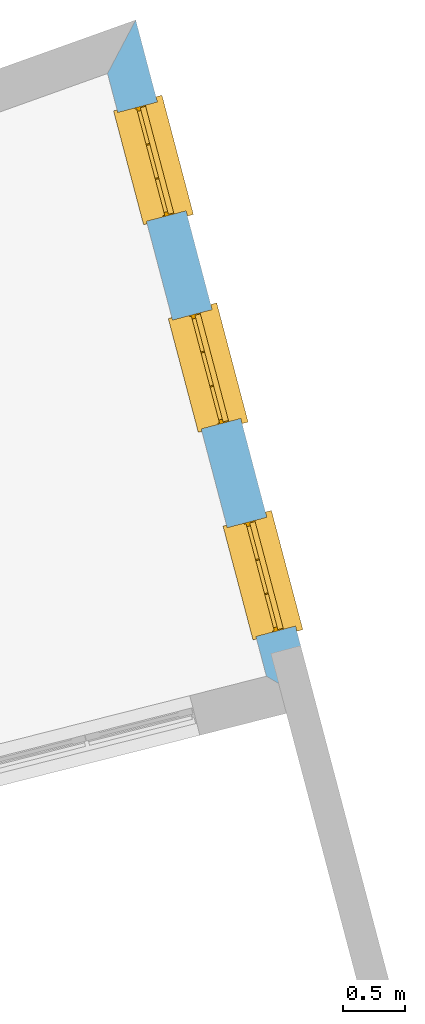
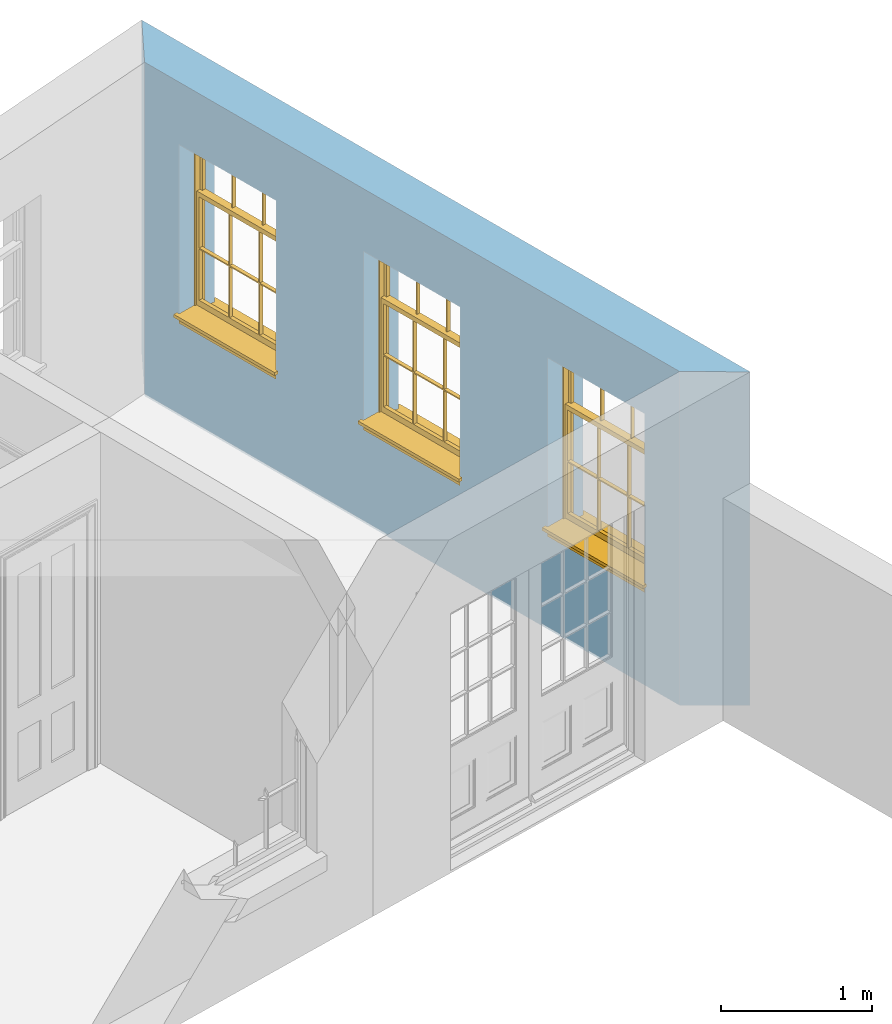
# One storey, part 14 of 15: 3 windows, 3 openings, plus 1 element that does not belong to this part.
"""IFC2X3 building model written with IfcOpenShell, lengths in metres."""

from ifc_helpers import new_model, si_unit, frame, origin, place, context, subcontext, project, spatial, polyline, outline, extrude, faceted_brep, material, layer, layer_set, layer_usage, element, fill, save


model = new_model("IFC2X3")

# Units and contexts
model_context = context("Model", 3, world=origin())
body_context = subcontext(model_context, "Body", "Model", "MODEL_VIEW")
ifc_project = project(units=[si_unit("PLANEANGLEUNIT", "RADIAN"), si_unit("MASSUNIT", "GRAM", prefix="KILO"), si_unit("FORCEUNIT", "NEWTON", prefix="KILO"), si_unit("LENGTHUNIT", "METRE")], contexts=[model_context])

# Site, building, storey
site_placement = place(None, origin())
site = spatial("IfcSite", under=ifc_project, at=site_placement, CompositionType="ELEMENT")
building_placement = place(None, origin())
building = spatial("IfcBuilding", under=site, at=building_placement, Name="Building plot-13", CompositionType="ELEMENT")
storey_placement = place(None, frame((0.0, 0.0, 4.0)))
storey = spatial("IfcBuildingStorey", under=building, at=storey_placement, Name="Floor 0", CompositionType="ELEMENT", Elevation=4.0)

# Wall, openings, windows
ifc_material = material(Name="Masonry")
ifc_layer = layer(ifc_material, 0.33, ventilated=False)
ifc_layer_set = layer_set([ifc_layer], Name="My Wall")
ifc_layer_usage = layer_usage(ifc_layer_set, "AXIS2", "NEGATIVE", 0.08)
wall_placement = place(storey_placement, origin())
wall = element("IfcWallStandardCase", 1, at=wall_placement, inside=storey, material=ifc_layer_usage, Name="exterior", context=body_context, shape_type="SweptSolid", body=[
    extrude(outline(polyline([(79.9817754258731, 47.2487256724398), (80.3857854678444, 47.0107450750622), (78.9265356735152, 52.5462115674965), (78.699089450727, 52.1144212259562), (79.9817754258731, 47.2487256724398)])), origin(), (0.0, 0.0, 1.0), 2.7),
])
opening_1_placement = place(storey_placement, frame((0.0, 0.0, 0.75)))
opening_1 = element("IfcOpeningElement", 2, at=opening_1_placement, cuts=wall, Name="Opening", ObjectType="Opening", context=body_context, shape_type="SweptSolid", body=[
    extrude(outline(polyline([(80.2165274414276, 47.6528024784256), (79.9845597414815, 48.5327405365761), (79.6654613247896, 48.4486203816506), (79.8974290247357, 47.5686823235001), (80.2165274414276, 47.6528024784256)])), origin(), (0.0, 0.0, 1.0), 1.445),
])
opening_2_placement = place(storey_placement, frame((0.0, 0.0, 0.75)))
opening_2 = element("IfcOpeningElement", 3, at=opening_2_placement, cuts=wall, Name="Opening", ObjectType="Opening", context=body_context, shape_type="SweptSolid", body=[
    extrude(outline(polyline([(79.7746976663439, 49.3288239004194), (79.5427299663978, 50.2087619585699), (79.2236315497059, 50.1246418036444), (79.455599249652, 49.2447037454939), (79.7746976663439, 49.3288239004194)])), origin(), (0.0, 0.0, 1.0), 1.445),
])
opening_3_placement = place(storey_placement, frame((0.0, 0.0, 0.75)))
opening_3 = element("IfcOpeningElement", 4, at=opening_3_placement, cuts=wall, Name="Opening", ObjectType="Opening", context=body_context, shape_type="SweptSolid", body=[
    extrude(outline(polyline([(79.3328678912602, 51.0048453224131), (79.1009001913141, 51.8847833805637), (78.7818017746222, 51.8006632256382), (79.0137694745683, 50.9207251674876), (79.3328678912602, 51.0048453224131)])), origin(), (0.0, 0.0, 1.0), 1.445),
])
window_1_placement = place(storey_placement, frame((79.974786216661, 47.5890750883305, 0.75), z_axis=(0.0, 0.0, 1.0), x_axis=(-0.231967699946068, 0.879938058150529, 0.0)))
window_1 = element("IfcWindow", 5, at=window_1_placement, inside=storey, Name="living street window", OverallHeight=1.445, OverallWidth=0.91, context=body_context, shape_type="Brep", held_by="IfcProductRepresentation", body=[
    faceted_brep([(0.876875, -0.105, 0.999097), (0.876875, -0.105, 1.411875), (0.9, -0.105, 1.435), (0.033125, -0.105, 1.411875), (0.033125, -0.105, 0.999097), (0.01, -0.105, 1.435), (0.033125, -0.135, 1.411875), (0.01, -0.135, 1.435), (0.033125, -0.135, 0.999097), (0.876875, -0.135, 1.411875), (0.876875, -0.135, 0.999097), (0.9, -0.135, 1.435), (0.033125, -0.105, 0.960972), (0.01, -0.105, 0.960972), (0.033125, -0.105, 0.548195), (0.876875, -0.105, 0.960972), (0.876875, -0.105, 0.548195), (0.9, -0.105, 0.960972), (0.876875, -0.105, 0.538195), (0.876875, -0.105, 0.125417), (0.9, -0.105, 0.077167), (0.033125, -0.105, 0.125417), (0.033125, -0.105, 0.538195), (0.01, -0.105, 0.077167), (0.9, -0.135, 0.960972), (0.01, -0.135, 0.960972), (-0.0425, -0.25, 0.01), (-0.0425, -0.3, 0.001667), (0.0, -0.25, 0.01), (0.9525, -0.25, 0.01), (0.91, -0.25, 0.01), (0.9525, -0.3, 0.001667), (-0.02, 0.08, 0.077167), (0.0, 0.08, 0.077167), (-0.02, 0.11, 0.077167), (0.0, -0.06, 0.077167), (0.01, -0.06, 0.077167), (0.91, -0.06, 0.077167), (0.91, 0.08, 0.077167), (0.9, -0.06, 0.077167), (0.93, 0.08, 0.077167), (0.93, 0.11, 0.077167), (0.01, -0.105, 0.999097), (0.01, -0.075, 0.999097), (0.9, -0.105, 0.999097), (0.9, -0.075, 0.999097), (0.876875, -0.075, 0.125417), (0.876875, -0.075, 0.538195), (0.9, -0.075, 0.077167), (0.876875, -0.075, 0.548195), (0.876875, -0.075, 0.960972), (0.033125, -0.075, 0.125417), (0.01, -0.075, 0.077167), (0.033125, -0.075, 0.538195), (0.033125, -0.075, 0.960972), (0.033125, -0.075, 0.548195), (-0.02, 0.08, 0.052167), (-0.02, 0.11, 0.052167), (0.93, 0.11, 0.052167), (0.93, 0.08, 0.052167), (0.91, 0.08, 0.052167), (0.0, 0.08, 0.052167), (0.91, -0.15, 0.026667), (0.0, -0.15, 0.026667), (-0.0425, -0.3, -0.123333), (0.9525, -0.3, -0.123333), (-0.0425, -0.25, -0.123333), (0.9525, -0.25, -0.123333), (0.01, -0.06, 1.435), (0.9, -0.06, 1.435), (0.0, -0.06, 1.445), (0.91, -0.06, 1.445), (0.01, -0.15, 0.077167), (0.9, -0.15, 0.077167), (0.592292, -0.105, 0.125417), (0.592292, -0.075, 0.125417), (0.317708, -0.075, 0.125417), (0.317708, -0.105, 0.125417), (0.592292, -0.105, 0.548195), (0.317708, -0.105, 0.548195), (0.317708, -0.105, 0.538195), (0.592292, -0.105, 0.538195), (0.592292, -0.075, 0.548195), (0.317708, -0.075, 0.548195), (0.602292, -0.075, 0.548195), (0.602292, -0.105, 0.548195), (0.317708, -0.075, 0.538195), (0.307708, -0.075, 0.125417), (0.307708, -0.075, 0.538195), (0.602292, -0.075, 0.538195), (0.602292, -0.075, 0.125417), (0.592292, -0.075, 0.538195), (0.307708, -0.075, 0.548195), (0.317708, -0.075, 0.960972), (0.307708, -0.075, 0.960972), (0.602292, -0.075, 0.960972), (0.592292, -0.075, 0.960972), (0.307708, -0.105, 0.538195), (0.307708, -0.105, 0.125417), (0.307708, -0.105, 0.548195), (0.307708, -0.105, 0.960972), (0.592292, -0.105, 0.960972), (0.317708, -0.105, 0.960972), (0.602292, -0.105, 0.960972), (0.602292, -0.105, 0.538195), (0.602292, -0.105, 0.125417), (0.317708, -0.135, 1.411875), (0.307708, -0.135, 1.411875), (0.307708, -0.135, 0.999097), (0.317708, -0.135, 0.999097), (0.602292, -0.135, 1.411875), (0.592292, -0.135, 1.411875), (0.592292, -0.135, 0.999097), (0.602292, -0.135, 0.999097), (0.317708, -0.105, 0.999097), (0.307708, -0.105, 0.999097), (0.307708, -0.105, 1.411875), (0.317708, -0.105, 1.411875), (0.602292, -0.105, 0.999097), (0.592292, -0.105, 0.999097), (0.592292, -0.105, 1.411875), (0.602292, -0.105, 1.411875), (0.91, -0.15, 1.445), (0.9, -0.15, 1.435), (0.01, -0.15, 1.435), (0.0, -0.15, 1.445), (0.91, -0.25, 0.0), (0.0, -0.25, 0.0), (0.91, 0.08, 0.0), (0.0, 0.08, 0.0)], [[[0, 1, 2]], [[3, 4, 5]], [[6, 7, 8]], [[9, 10, 11]], [[12, 13, 14]], [[15, 16, 17]], [[18, 19, 20]], [[21, 22, 23]], [[24, 15, 17]], [[13, 12, 25]], [[26, 27, 28]], [[29, 30, 31]], [[32, 33, 34]], [[35, 36, 33]], [[37, 38, 39]], [[40, 41, 38]], [[42, 4, 43]], [[44, 45, 0]], [[46, 47, 48]], [[49, 50, 45]], [[51, 52, 53]], [[54, 55, 43]], [[38, 33, 36, 39]], [[41, 34, 33, 38]], [[56, 32, 34, 57]], [[57, 34, 41, 58]], [[58, 41, 40, 59]], [[57, 58, 60, 61]], [[52, 48, 39, 36]], [[62, 63, 28, 30]], [[27, 31, 30, 28]], [[27, 64, 65, 31]], [[66, 67, 65, 64]], [[2, 5, 68, 69]], [[68, 70, 71, 69]], [[20, 23, 72, 73]], [[73, 72, 63, 62]], [[74, 75, 76, 77]], [[78, 79, 80, 81]], [[78, 82, 83, 79]], [[16, 49, 84, 85]], [[86, 76, 87, 88]], [[89, 90, 75, 91]], [[92, 88, 53, 55]], [[82, 91, 86, 83]], [[93, 83, 92, 94]], [[95, 84, 82, 96]], [[89, 84, 49, 47]], [[97, 88, 87, 98]], [[22, 53, 88, 97]], [[81, 91, 75, 74]], [[80, 86, 91, 81]], [[77, 76, 86, 80]], [[99, 92, 55, 14]], [[100, 94, 92, 99]], [[101, 96, 82, 78]], [[79, 83, 93, 102]], [[85, 84, 95, 103]], [[104, 89, 47, 18]], [[105, 90, 89, 104]], [[104, 18, 16, 85]], [[80, 97, 98, 77]], [[104, 81, 74, 105]], [[103, 101, 78, 85]], [[99, 14, 22, 97]], [[102, 100, 99, 79]], [[106, 107, 108, 109]], [[110, 111, 112, 113]], [[114, 115, 116, 117]], [[118, 119, 120, 121]], [[107, 116, 115, 108]], [[111, 120, 119, 112]], [[109, 114, 117, 106]], [[113, 118, 121, 110]], [[85, 78, 81, 104]], [[84, 89, 91, 82]], [[83, 86, 88, 92]], [[79, 99, 97, 80]], [[109, 112, 119, 114]], [[102, 93, 96, 101]], [[106, 117, 120, 111]], [[98, 87, 51, 21]], [[6, 3, 116, 107]], [[110, 121, 1, 9]], [[19, 46, 90, 105]], [[26, 66, 64, 27]], [[29, 31, 65, 67]], [[25, 24, 112, 109]], [[11, 7, 106, 111]], [[75, 48, 52, 76]], [[43, 45, 96, 93]], [[45, 43, 114, 119]], [[5, 2, 120, 117]], [[24, 25, 102, 101]], [[42, 5, 4]], [[2, 44, 0]], [[49, 45, 48, 47]], [[52, 43, 55, 53]], [[14, 13, 23, 22]], [[20, 17, 16, 18]], [[24, 11, 10]], [[25, 8, 7]], [[8, 4, 3, 6]], [[9, 1, 0, 10]], [[15, 50, 49, 16]], [[18, 47, 46, 19]], [[21, 51, 53, 22]], [[14, 55, 54, 12]], [[44, 2, 69, 45]], [[68, 5, 42, 43]], [[36, 35, 70, 68]], [[39, 69, 71, 37]], [[62, 122, 123, 73]], [[63, 72, 124, 125]], [[8, 108, 115, 4]], [[113, 10, 0, 118]], [[94, 100, 12, 54]], [[17, 20, 73, 24]], [[72, 23, 13, 25]], [[52, 36, 68, 43]], [[69, 39, 48, 45]], [[11, 24, 73, 123]], [[7, 124, 72, 25]], [[23, 77, 98]], [[98, 21, 23]], [[105, 74, 20]], [[20, 19, 105]], [[20, 74, 77, 23]], [[113, 112, 24]], [[24, 10, 113]], [[25, 109, 108]], [[108, 8, 25]], [[110, 9, 11]], [[11, 111, 110]], [[7, 6, 107]], [[107, 106, 7]], [[5, 117, 116]], [[116, 3, 5]], [[121, 120, 2]], [[2, 1, 121]], [[11, 123, 124, 7]], [[122, 125, 124, 123]], [[43, 93, 94]], [[94, 54, 43]], [[96, 45, 95]], [[50, 95, 45]], [[15, 103, 95, 50]], [[48, 75, 90]], [[90, 46, 48]], [[87, 76, 52]], [[52, 51, 87]], [[103, 15, 24]], [[24, 101, 103]], [[100, 102, 25]], [[25, 12, 100]], [[115, 114, 43]], [[43, 4, 115]], [[118, 0, 45]], [[45, 119, 118]], [[71, 70, 125, 122]], [[70, 35, 63, 125]], [[122, 62, 37, 71]], [[126, 67, 66, 127]], [[60, 58, 59]], [[38, 60, 59, 40]], [[61, 56, 57]], [[32, 56, 61, 33]], [[61, 60, 128, 129]], [[62, 60, 38, 37]], [[126, 128, 60, 62]], [[33, 61, 63, 35]], [[61, 129, 127, 63]], [[128, 126, 127, 129]], [[28, 127, 66, 26]], [[63, 127, 28]], [[29, 67, 126, 30]], [[30, 126, 62]]]),
])
fill(opening_1, window_1)
window_2_placement = place(storey_placement, frame((79.5329564415773, 49.2650965103243, 0.75), z_axis=(0.0, 0.0, 1.0), x_axis=(-0.231967699946068, 0.879938058150529, 0.0)))
window_2 = element("IfcWindow", 6, at=window_2_placement, inside=storey, Name="living street window", OverallHeight=1.445, OverallWidth=0.91, context=body_context, shape_type="Brep", held_by="IfcProductRepresentation", body=[
    faceted_brep([(0.876875, -0.105, 0.999097), (0.876875, -0.105, 1.411875), (0.9, -0.105, 1.435), (0.033125, -0.105, 1.411875), (0.033125, -0.105, 0.999097), (0.01, -0.105, 1.435), (0.033125, -0.135, 1.411875), (0.01, -0.135, 1.435), (0.033125, -0.135, 0.999097), (0.876875, -0.135, 1.411875), (0.876875, -0.135, 0.999097), (0.9, -0.135, 1.435), (0.033125, -0.105, 0.960972), (0.01, -0.105, 0.960972), (0.033125, -0.105, 0.548195), (0.876875, -0.105, 0.960972), (0.876875, -0.105, 0.548195), (0.9, -0.105, 0.960972), (0.876875, -0.105, 0.538195), (0.876875, -0.105, 0.125417), (0.9, -0.105, 0.077167), (0.033125, -0.105, 0.125417), (0.033125, -0.105, 0.538195), (0.01, -0.105, 0.077167), (0.9, -0.135, 0.960972), (0.01, -0.135, 0.960972), (-0.0425, -0.25, 0.01), (-0.0425, -0.3, 0.001667), (0.0, -0.25, 0.01), (0.9525, -0.25, 0.01), (0.91, -0.25, 0.01), (0.9525, -0.3, 0.001667), (-0.02, 0.08, 0.077167), (0.0, 0.08, 0.077167), (-0.02, 0.11, 0.077167), (0.0, -0.06, 0.077167), (0.01, -0.06, 0.077167), (0.91, -0.06, 0.077167), (0.91, 0.08, 0.077167), (0.9, -0.06, 0.077167), (0.93, 0.08, 0.077167), (0.93, 0.11, 0.077167), (0.01, -0.105, 0.999097), (0.01, -0.075, 0.999097), (0.9, -0.105, 0.999097), (0.9, -0.075, 0.999097), (0.876875, -0.075, 0.125417), (0.876875, -0.075, 0.538195), (0.9, -0.075, 0.077167), (0.876875, -0.075, 0.548195), (0.876875, -0.075, 0.960972), (0.033125, -0.075, 0.125417), (0.01, -0.075, 0.077167), (0.033125, -0.075, 0.538195), (0.033125, -0.075, 0.960972), (0.033125, -0.075, 0.548195), (-0.02, 0.08, 0.052167), (-0.02, 0.11, 0.052167), (0.93, 0.11, 0.052167), (0.93, 0.08, 0.052167), (0.91, 0.08, 0.052167), (0.0, 0.08, 0.052167), (0.91, -0.15, 0.026667), (0.0, -0.15, 0.026667), (-0.0425, -0.3, -0.123333), (0.9525, -0.3, -0.123333), (-0.0425, -0.25, -0.123333), (0.9525, -0.25, -0.123333), (0.01, -0.06, 1.435), (0.9, -0.06, 1.435), (0.0, -0.06, 1.445), (0.91, -0.06, 1.445), (0.01, -0.15, 0.077167), (0.9, -0.15, 0.077167), (0.592292, -0.105, 0.125417), (0.592292, -0.075, 0.125417), (0.317708, -0.075, 0.125417), (0.317708, -0.105, 0.125417), (0.592292, -0.105, 0.548195), (0.317708, -0.105, 0.548195), (0.317708, -0.105, 0.538195), (0.592292, -0.105, 0.538195), (0.592292, -0.075, 0.548195), (0.317708, -0.075, 0.548195), (0.602292, -0.075, 0.548195), (0.602292, -0.105, 0.548195), (0.317708, -0.075, 0.538195), (0.307708, -0.075, 0.125417), (0.307708, -0.075, 0.538195), (0.602292, -0.075, 0.538195), (0.602292, -0.075, 0.125417), (0.592292, -0.075, 0.538195), (0.307708, -0.075, 0.548195), (0.317708, -0.075, 0.960972), (0.307708, -0.075, 0.960972), (0.602292, -0.075, 0.960972), (0.592292, -0.075, 0.960972), (0.307708, -0.105, 0.538195), (0.307708, -0.105, 0.125417), (0.307708, -0.105, 0.548195), (0.307708, -0.105, 0.960972), (0.592292, -0.105, 0.960972), (0.317708, -0.105, 0.960972), (0.602292, -0.105, 0.960972), (0.602292, -0.105, 0.538195), (0.602292, -0.105, 0.125417), (0.317708, -0.135, 1.411875), (0.307708, -0.135, 1.411875), (0.307708, -0.135, 0.999097), (0.317708, -0.135, 0.999097), (0.602292, -0.135, 1.411875), (0.592292, -0.135, 1.411875), (0.592292, -0.135, 0.999097), (0.602292, -0.135, 0.999097), (0.317708, -0.105, 0.999097), (0.307708, -0.105, 0.999097), (0.307708, -0.105, 1.411875), (0.317708, -0.105, 1.411875), (0.602292, -0.105, 0.999097), (0.592292, -0.105, 0.999097), (0.592292, -0.105, 1.411875), (0.602292, -0.105, 1.411875), (0.91, -0.15, 1.445), (0.9, -0.15, 1.435), (0.01, -0.15, 1.435), (0.0, -0.15, 1.445), (0.91, -0.25, 0.0), (0.0, -0.25, 0.0), (0.91, 0.08, 0.0), (0.0, 0.08, 0.0)], [[[0, 1, 2]], [[3, 4, 5]], [[6, 7, 8]], [[9, 10, 11]], [[12, 13, 14]], [[15, 16, 17]], [[18, 19, 20]], [[21, 22, 23]], [[24, 15, 17]], [[13, 12, 25]], [[26, 27, 28]], [[29, 30, 31]], [[32, 33, 34]], [[35, 36, 33]], [[37, 38, 39]], [[40, 41, 38]], [[42, 4, 43]], [[44, 45, 0]], [[46, 47, 48]], [[49, 50, 45]], [[51, 52, 53]], [[54, 55, 43]], [[38, 33, 36, 39]], [[41, 34, 33, 38]], [[56, 32, 34, 57]], [[57, 34, 41, 58]], [[58, 41, 40, 59]], [[57, 58, 60, 61]], [[52, 48, 39, 36]], [[62, 63, 28, 30]], [[27, 31, 30, 28]], [[27, 64, 65, 31]], [[66, 67, 65, 64]], [[2, 5, 68, 69]], [[68, 70, 71, 69]], [[20, 23, 72, 73]], [[73, 72, 63, 62]], [[74, 75, 76, 77]], [[78, 79, 80, 81]], [[78, 82, 83, 79]], [[16, 49, 84, 85]], [[86, 76, 87, 88]], [[89, 90, 75, 91]], [[92, 88, 53, 55]], [[82, 91, 86, 83]], [[93, 83, 92, 94]], [[95, 84, 82, 96]], [[89, 84, 49, 47]], [[97, 88, 87, 98]], [[22, 53, 88, 97]], [[81, 91, 75, 74]], [[80, 86, 91, 81]], [[77, 76, 86, 80]], [[99, 92, 55, 14]], [[100, 94, 92, 99]], [[101, 96, 82, 78]], [[79, 83, 93, 102]], [[85, 84, 95, 103]], [[104, 89, 47, 18]], [[105, 90, 89, 104]], [[104, 18, 16, 85]], [[80, 97, 98, 77]], [[104, 81, 74, 105]], [[103, 101, 78, 85]], [[99, 14, 22, 97]], [[102, 100, 99, 79]], [[106, 107, 108, 109]], [[110, 111, 112, 113]], [[114, 115, 116, 117]], [[118, 119, 120, 121]], [[107, 116, 115, 108]], [[111, 120, 119, 112]], [[109, 114, 117, 106]], [[113, 118, 121, 110]], [[85, 78, 81, 104]], [[84, 89, 91, 82]], [[83, 86, 88, 92]], [[79, 99, 97, 80]], [[109, 112, 119, 114]], [[102, 93, 96, 101]], [[106, 117, 120, 111]], [[98, 87, 51, 21]], [[6, 3, 116, 107]], [[110, 121, 1, 9]], [[19, 46, 90, 105]], [[26, 66, 64, 27]], [[29, 31, 65, 67]], [[25, 24, 112, 109]], [[11, 7, 106, 111]], [[75, 48, 52, 76]], [[43, 45, 96, 93]], [[45, 43, 114, 119]], [[5, 2, 120, 117]], [[24, 25, 102, 101]], [[42, 5, 4]], [[2, 44, 0]], [[49, 45, 48, 47]], [[52, 43, 55, 53]], [[14, 13, 23, 22]], [[20, 17, 16, 18]], [[24, 11, 10]], [[25, 8, 7]], [[8, 4, 3, 6]], [[9, 1, 0, 10]], [[15, 50, 49, 16]], [[18, 47, 46, 19]], [[21, 51, 53, 22]], [[14, 55, 54, 12]], [[44, 2, 69, 45]], [[68, 5, 42, 43]], [[36, 35, 70, 68]], [[39, 69, 71, 37]], [[62, 122, 123, 73]], [[63, 72, 124, 125]], [[8, 108, 115, 4]], [[113, 10, 0, 118]], [[94, 100, 12, 54]], [[17, 20, 73, 24]], [[72, 23, 13, 25]], [[52, 36, 68, 43]], [[69, 39, 48, 45]], [[11, 24, 73, 123]], [[7, 124, 72, 25]], [[23, 77, 98]], [[98, 21, 23]], [[105, 74, 20]], [[20, 19, 105]], [[20, 74, 77, 23]], [[113, 112, 24]], [[24, 10, 113]], [[25, 109, 108]], [[108, 8, 25]], [[110, 9, 11]], [[11, 111, 110]], [[7, 6, 107]], [[107, 106, 7]], [[5, 117, 116]], [[116, 3, 5]], [[121, 120, 2]], [[2, 1, 121]], [[11, 123, 124, 7]], [[122, 125, 124, 123]], [[43, 93, 94]], [[94, 54, 43]], [[96, 45, 95]], [[50, 95, 45]], [[15, 103, 95, 50]], [[48, 75, 90]], [[90, 46, 48]], [[87, 76, 52]], [[52, 51, 87]], [[103, 15, 24]], [[24, 101, 103]], [[100, 102, 25]], [[25, 12, 100]], [[115, 114, 43]], [[43, 4, 115]], [[118, 0, 45]], [[45, 119, 118]], [[71, 70, 125, 122]], [[70, 35, 63, 125]], [[122, 62, 37, 71]], [[126, 67, 66, 127]], [[60, 58, 59]], [[38, 60, 59, 40]], [[61, 56, 57]], [[32, 56, 61, 33]], [[61, 60, 128, 129]], [[62, 60, 38, 37]], [[126, 128, 60, 62]], [[33, 61, 63, 35]], [[61, 129, 127, 63]], [[128, 126, 127, 129]], [[28, 127, 66, 26]], [[63, 127, 28]], [[29, 67, 126, 30]], [[30, 126, 62]]]),
])
fill(opening_2, window_2)
window_3_placement = place(storey_placement, frame((79.0911266664936, 50.9411179323181, 0.75), z_axis=(0.0, 0.0, 1.0), x_axis=(-0.231967699946068, 0.879938058150529, 0.0)))
window_3 = element("IfcWindow", 7, at=window_3_placement, inside=storey, Name="living street window", OverallHeight=1.445, OverallWidth=0.91, context=body_context, shape_type="Brep", held_by="IfcProductRepresentation", body=[
    faceted_brep([(0.876875, -0.105, 0.999097), (0.876875, -0.105, 1.411875), (0.9, -0.105, 1.435), (0.033125, -0.105, 1.411875), (0.033125, -0.105, 0.999097), (0.01, -0.105, 1.435), (0.033125, -0.135, 1.411875), (0.01, -0.135, 1.435), (0.033125, -0.135, 0.999097), (0.876875, -0.135, 1.411875), (0.876875, -0.135, 0.999097), (0.9, -0.135, 1.435), (0.033125, -0.105, 0.960972), (0.01, -0.105, 0.960972), (0.033125, -0.105, 0.548195), (0.876875, -0.105, 0.960972), (0.876875, -0.105, 0.548195), (0.9, -0.105, 0.960972), (0.876875, -0.105, 0.538195), (0.876875, -0.105, 0.125417), (0.9, -0.105, 0.077167), (0.033125, -0.105, 0.125417), (0.033125, -0.105, 0.538195), (0.01, -0.105, 0.077167), (0.9, -0.135, 0.960972), (0.01, -0.135, 0.960972), (-0.0425, -0.25, 0.01), (-0.0425, -0.3, 0.001667), (0.0, -0.25, 0.01), (0.9525, -0.25, 0.01), (0.91, -0.25, 0.01), (0.9525, -0.3, 0.001667), (-0.02, 0.08, 0.077167), (0.0, 0.08, 0.077167), (-0.02, 0.11, 0.077167), (0.0, -0.06, 0.077167), (0.01, -0.06, 0.077167), (0.91, -0.06, 0.077167), (0.91, 0.08, 0.077167), (0.9, -0.06, 0.077167), (0.93, 0.08, 0.077167), (0.93, 0.11, 0.077167), (0.01, -0.105, 0.999097), (0.01, -0.075, 0.999097), (0.9, -0.105, 0.999097), (0.9, -0.075, 0.999097), (0.876875, -0.075, 0.125417), (0.876875, -0.075, 0.538195), (0.9, -0.075, 0.077167), (0.876875, -0.075, 0.548195), (0.876875, -0.075, 0.960972), (0.033125, -0.075, 0.125417), (0.01, -0.075, 0.077167), (0.033125, -0.075, 0.538195), (0.033125, -0.075, 0.960972), (0.033125, -0.075, 0.548195), (-0.02, 0.08, 0.052167), (-0.02, 0.11, 0.052167), (0.93, 0.11, 0.052167), (0.93, 0.08, 0.052167), (0.91, 0.08, 0.052167), (0.0, 0.08, 0.052167), (0.91, -0.15, 0.026667), (0.0, -0.15, 0.026667), (-0.0425, -0.3, -0.123333), (0.9525, -0.3, -0.123333), (-0.0425, -0.25, -0.123333), (0.9525, -0.25, -0.123333), (0.01, -0.06, 1.435), (0.9, -0.06, 1.435), (0.0, -0.06, 1.445), (0.91, -0.06, 1.445), (0.01, -0.15, 0.077167), (0.9, -0.15, 0.077167), (0.592292, -0.105, 0.125417), (0.592292, -0.075, 0.125417), (0.317708, -0.075, 0.125417), (0.317708, -0.105, 0.125417), (0.592292, -0.105, 0.548195), (0.317708, -0.105, 0.548195), (0.317708, -0.105, 0.538195), (0.592292, -0.105, 0.538195), (0.592292, -0.075, 0.548195), (0.317708, -0.075, 0.548195), (0.602292, -0.075, 0.548195), (0.602292, -0.105, 0.548195), (0.317708, -0.075, 0.538195), (0.307708, -0.075, 0.125417), (0.307708, -0.075, 0.538195), (0.602292, -0.075, 0.538195), (0.602292, -0.075, 0.125417), (0.592292, -0.075, 0.538195), (0.307708, -0.075, 0.548195), (0.317708, -0.075, 0.960972), (0.307708, -0.075, 0.960972), (0.602292, -0.075, 0.960972), (0.592292, -0.075, 0.960972), (0.307708, -0.105, 0.538195), (0.307708, -0.105, 0.125417), (0.307708, -0.105, 0.548195), (0.307708, -0.105, 0.960972), (0.592292, -0.105, 0.960972), (0.317708, -0.105, 0.960972), (0.602292, -0.105, 0.960972), (0.602292, -0.105, 0.538195), (0.602292, -0.105, 0.125417), (0.317708, -0.135, 1.411875), (0.307708, -0.135, 1.411875), (0.307708, -0.135, 0.999097), (0.317708, -0.135, 0.999097), (0.602292, -0.135, 1.411875), (0.592292, -0.135, 1.411875), (0.592292, -0.135, 0.999097), (0.602292, -0.135, 0.999097), (0.317708, -0.105, 0.999097), (0.307708, -0.105, 0.999097), (0.307708, -0.105, 1.411875), (0.317708, -0.105, 1.411875), (0.602292, -0.105, 0.999097), (0.592292, -0.105, 0.999097), (0.592292, -0.105, 1.411875), (0.602292, -0.105, 1.411875), (0.91, -0.15, 1.445), (0.9, -0.15, 1.435), (0.01, -0.15, 1.435), (0.0, -0.15, 1.445), (0.91, -0.25, 0.0), (0.0, -0.25, 0.0), (0.91, 0.08, 0.0), (0.0, 0.08, 0.0)], [[[0, 1, 2]], [[3, 4, 5]], [[6, 7, 8]], [[9, 10, 11]], [[12, 13, 14]], [[15, 16, 17]], [[18, 19, 20]], [[21, 22, 23]], [[24, 15, 17]], [[13, 12, 25]], [[26, 27, 28]], [[29, 30, 31]], [[32, 33, 34]], [[35, 36, 33]], [[37, 38, 39]], [[40, 41, 38]], [[42, 4, 43]], [[44, 45, 0]], [[46, 47, 48]], [[49, 50, 45]], [[51, 52, 53]], [[54, 55, 43]], [[38, 33, 36, 39]], [[41, 34, 33, 38]], [[56, 32, 34, 57]], [[57, 34, 41, 58]], [[58, 41, 40, 59]], [[57, 58, 60, 61]], [[52, 48, 39, 36]], [[62, 63, 28, 30]], [[27, 31, 30, 28]], [[27, 64, 65, 31]], [[66, 67, 65, 64]], [[2, 5, 68, 69]], [[68, 70, 71, 69]], [[20, 23, 72, 73]], [[73, 72, 63, 62]], [[74, 75, 76, 77]], [[78, 79, 80, 81]], [[78, 82, 83, 79]], [[16, 49, 84, 85]], [[86, 76, 87, 88]], [[89, 90, 75, 91]], [[92, 88, 53, 55]], [[82, 91, 86, 83]], [[93, 83, 92, 94]], [[95, 84, 82, 96]], [[89, 84, 49, 47]], [[97, 88, 87, 98]], [[22, 53, 88, 97]], [[81, 91, 75, 74]], [[80, 86, 91, 81]], [[77, 76, 86, 80]], [[99, 92, 55, 14]], [[100, 94, 92, 99]], [[101, 96, 82, 78]], [[79, 83, 93, 102]], [[85, 84, 95, 103]], [[104, 89, 47, 18]], [[105, 90, 89, 104]], [[104, 18, 16, 85]], [[80, 97, 98, 77]], [[104, 81, 74, 105]], [[103, 101, 78, 85]], [[99, 14, 22, 97]], [[102, 100, 99, 79]], [[106, 107, 108, 109]], [[110, 111, 112, 113]], [[114, 115, 116, 117]], [[118, 119, 120, 121]], [[107, 116, 115, 108]], [[111, 120, 119, 112]], [[109, 114, 117, 106]], [[113, 118, 121, 110]], [[85, 78, 81, 104]], [[84, 89, 91, 82]], [[83, 86, 88, 92]], [[79, 99, 97, 80]], [[109, 112, 119, 114]], [[102, 93, 96, 101]], [[106, 117, 120, 111]], [[98, 87, 51, 21]], [[6, 3, 116, 107]], [[110, 121, 1, 9]], [[19, 46, 90, 105]], [[26, 66, 64, 27]], [[29, 31, 65, 67]], [[25, 24, 112, 109]], [[11, 7, 106, 111]], [[75, 48, 52, 76]], [[43, 45, 96, 93]], [[45, 43, 114, 119]], [[5, 2, 120, 117]], [[24, 25, 102, 101]], [[42, 5, 4]], [[2, 44, 0]], [[49, 45, 48, 47]], [[52, 43, 55, 53]], [[14, 13, 23, 22]], [[20, 17, 16, 18]], [[24, 11, 10]], [[25, 8, 7]], [[8, 4, 3, 6]], [[9, 1, 0, 10]], [[15, 50, 49, 16]], [[18, 47, 46, 19]], [[21, 51, 53, 22]], [[14, 55, 54, 12]], [[44, 2, 69, 45]], [[68, 5, 42, 43]], [[36, 35, 70, 68]], [[39, 69, 71, 37]], [[62, 122, 123, 73]], [[63, 72, 124, 125]], [[8, 108, 115, 4]], [[113, 10, 0, 118]], [[94, 100, 12, 54]], [[17, 20, 73, 24]], [[72, 23, 13, 25]], [[52, 36, 68, 43]], [[69, 39, 48, 45]], [[11, 24, 73, 123]], [[7, 124, 72, 25]], [[23, 77, 98]], [[98, 21, 23]], [[105, 74, 20]], [[20, 19, 105]], [[20, 74, 77, 23]], [[113, 112, 24]], [[24, 10, 113]], [[25, 109, 108]], [[108, 8, 25]], [[110, 9, 11]], [[11, 111, 110]], [[7, 6, 107]], [[107, 106, 7]], [[5, 117, 116]], [[116, 3, 5]], [[121, 120, 2]], [[2, 1, 121]], [[11, 123, 124, 7]], [[122, 125, 124, 123]], [[43, 93, 94]], [[94, 54, 43]], [[96, 45, 95]], [[50, 95, 45]], [[15, 103, 95, 50]], [[48, 75, 90]], [[90, 46, 48]], [[87, 76, 52]], [[52, 51, 87]], [[103, 15, 24]], [[24, 101, 103]], [[100, 102, 25]], [[25, 12, 100]], [[115, 114, 43]], [[43, 4, 115]], [[118, 0, 45]], [[45, 119, 118]], [[71, 70, 125, 122]], [[70, 35, 63, 125]], [[122, 62, 37, 71]], [[126, 67, 66, 127]], [[60, 58, 59]], [[38, 60, 59, 40]], [[61, 56, 57]], [[32, 56, 61, 33]], [[61, 60, 128, 129]], [[62, 60, 38, 37]], [[126, 128, 60, 62]], [[33, 61, 63, 35]], [[61, 129, 127, 63]], [[128, 126, 127, 129]], [[28, 127, 66, 26]], [[63, 127, 28]], [[29, 67, 126, 30]], [[30, 126, 62]]]),
])
fill(opening_3, window_3)

save(model, "model.ifc")
